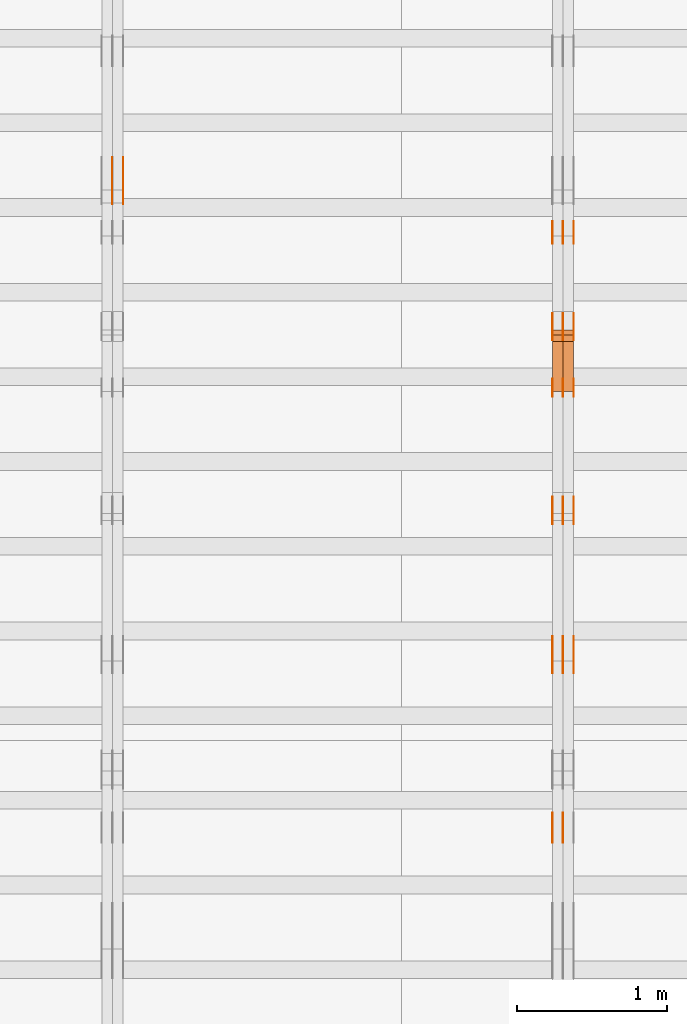
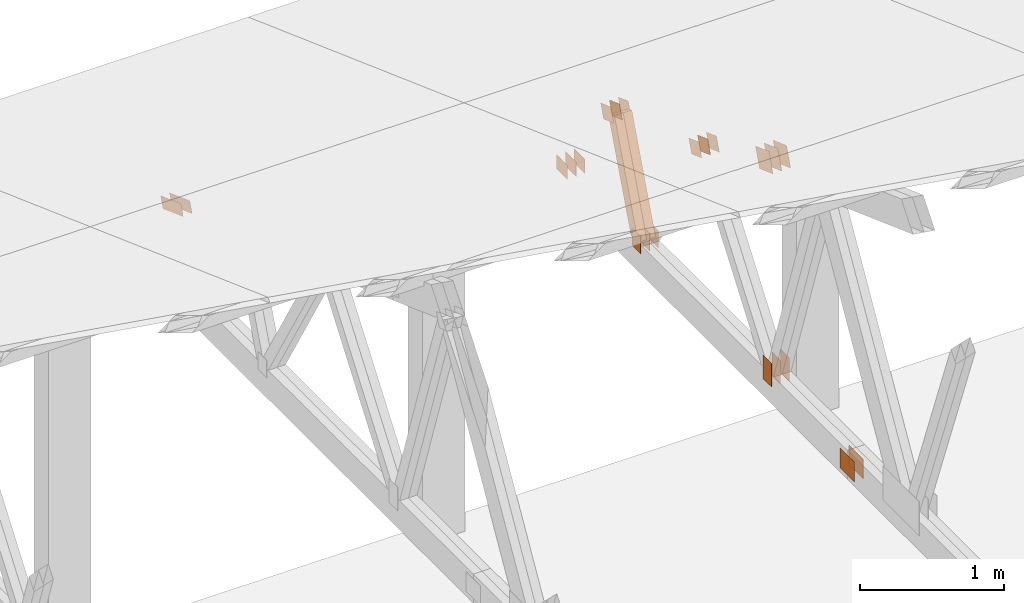
# One storey, part 166 of 189: 31 proxies.
"""IFC2X3 building model written with IfcOpenShell, lengths in millimetres."""

import ifcopenshell
import ifcopenshell.guid

model = None  # the IFC model being written
_history = None  # IfcOwnerHistory: only IFC2X3 demands one
_inside = {}  # id of a spatial element -> (the spatial element, [elements in it])
_under = {}  # id of a project, library or spatial element -> (it, [spatial elements below it])
_declared = {}  # id of a project -> (the project, [libraries it declares])
_typed = {}  # id of a type object -> (the type object, [elements of that type])
_made_of = {}  # id of a material, layer set ... -> (it, [elements and type objects made of it])


def new_model(schema):
    """Start an empty IFC model of exactly this schema.

    Asked for "IFC4X3", IfcOpenShell would pick the latest addendum, in which some entities
    have other attributes; the version numbers below select the first issue.
    IFC2X3 requires an IfcOwnerHistory on every rooted entity: one is made here for all.
    """
    global model, _history
    if schema == "IFC4X3":
        model = ifcopenshell.file(schema_version=(4, 3, 0, 0))
    else:
        model = ifcopenshell.file(schema=schema)
    _inside.clear()
    _under.clear()
    _declared.clear()
    _typed.clear()
    _made_of.clear()
    _history = None
    if model.schema == "IFC2X3":
        org = make("IfcOrganization", Name="unknown")
        user = make(
            "IfcPersonAndOrganization",
            ThePerson=make("IfcPerson", FamilyName="unknown"),
            TheOrganization=org,
        )
        app = make(
            "IfcApplication",
            ApplicationDeveloper=org,
            Version="unknown",
            ApplicationFullName="unknown",
            ApplicationIdentifier="unknown",
        )
        _history = make(
            "IfcOwnerHistory",
            OwningUser=user,
            OwningApplication=app,
            ChangeAction="ADDED",
            CreationDate=0,
        )
    return model


def make(cls, **values):
    """One entity of the class cls with the attributes given. An attribute that is None is left unset."""
    return model.create_entity(
        cls, **{name: value for name, value in values.items() if value is not None}
    )


def entity(cls, *values):
    """Any entity or typed value of the class cls, its attributes in the order of the schema. None: left unset."""
    e = model.create_entity(cls)
    for i, value in enumerate(values):
        if value is not None:
            e[i] = value
    return e


def rooted(cls, **values):
    """An entity with a GlobalId (a new one), such as an element, a storey or a relation."""
    return make(cls, GlobalId=ifcopenshell.guid.new(), OwnerHistory=_history, **values)


def si_unit(unit_type, name, prefix=None):
    """IfcSIUnit, for example si_unit("LENGTHUNIT", "METRE", prefix="MILLI")."""
    return make("IfcSIUnit", UnitType=unit_type, Prefix=prefix, Name=name)


def converted_unit(unit_type, name, factor, base, dimensions=None, offset=None):
    """IfcConversionBasedUnit, such as the inch: factor (a typed value) times the base unit."""
    return make(
        "IfcConversionBasedUnit"
        if offset is None
        else "IfcConversionBasedUnitWithOffset",
        ConversionOffset=offset,
        Dimensions=None
        if dimensions is None
        else entity("IfcDimensionalExponents", *dimensions),
        UnitType=unit_type,
        Name=name,
        ConversionFactor=make(
            "IfcMeasureWithUnit", ValueComponent=factor, UnitComponent=base
        ),
    )


def derived_unit(unit_type, elements):
    """IfcDerivedUnit: a product of units, each with its exponent."""
    return make(
        "IfcDerivedUnit",
        Elements=[
            make("IfcDerivedUnitElement", Unit=unit, Exponent=power)
            for unit, power in elements
        ],
        UnitType=unit_type,
    )


def assignment(units):
    """IfcUnitAssignment: the units of a project."""
    return None if units is None else make("IfcUnitAssignment", Units=units)


def point(xyz):
    """IfcCartesianPoint."""
    return None if xyz is None else make("IfcCartesianPoint", Coordinates=xyz)


def direction(xyz):
    """IfcDirection."""
    return None if xyz is None else make("IfcDirection", DirectionRatios=xyz)


def frame(location, z_axis=None, x_axis=None):
    """IfcAxis2Placement3D, a coordinate frame: its origin and axes. An axis left out is left unset."""
    return make(
        "IfcAxis2Placement3D",
        Location=point(location),
        Axis=direction(z_axis),
        RefDirection=direction(x_axis),
    )


def frame_2d(location, x_axis=None):
    """IfcAxis2Placement2D, a coordinate frame in the plane: its origin and x axis."""
    return make(
        "IfcAxis2Placement2D", Location=point(location), RefDirection=direction(x_axis)
    )


def origin():
    """The frame at (0, 0, 0) with its axes left unset."""
    return frame((0.0, 0.0, 0.0))


def origin_2d_with_axis():
    """The frame at (0, 0) in the plane with the x axis (1, 0) written out."""
    return frame_2d((0.0, 0.0), x_axis=(1.0, 0.0))


def place(relative_to, where):
    """IfcLocalPlacement: puts the frame where relative to a parent placement (None: the world)."""
    return make(
        "IfcLocalPlacement", PlacementRelTo=relative_to, RelativePlacement=where
    )


def context(
    kind, dimensions, precision=None, world=None, true_north=None, identifier=None
):
    """IfcGeometricRepresentationContext, for example the 3D "Model" context."""
    return make(
        "IfcGeometricRepresentationContext",
        ContextIdentifier=identifier,
        ContextType=kind,
        CoordinateSpaceDimension=dimensions,
        Precision=precision,
        WorldCoordinateSystem=world,
        TrueNorth=true_north,
    )


def subcontext(parent, identifier, kind, view, scale=None):
    """IfcGeometricRepresentationSubContext, for example "Body" below "Model"."""
    return make(
        "IfcGeometricRepresentationSubContext",
        ContextIdentifier=identifier,
        ContextType=kind,
        ParentContext=parent,
        TargetScale=scale,
        TargetView=view,
    )


def project(units=None, contexts=None):
    """IfcProject with its units and contexts."""
    return rooted(
        "IfcProject",
        Name="project",
        RepresentationContexts=contexts,
        UnitsInContext=assignment(units),
    )


def spatial(cls, under=None, at=None, **own):
    """A site, building, storey or space (cls), placed at a placement, below another one or the project."""
    s = rooted(cls, ObjectPlacement=at, **own)
    if under is not None:
        _under.setdefault(under.id(), (under, []))[1].append(s)
    return s


def polyline(points):
    """IfcPolyline through the points."""
    return make("IfcPolyline", Points=[point(p) for p in points])


def profile(cls, at=None, kind="AREA", **sizes):
    """A parametric profile (cls). Its sizes go by their IFC names, for example OverallWidth=200.0."""
    return make(cls, ProfileType=kind, Position=at, **sizes)


def rectangle(**sizes):
    """IfcRectangleProfileDef."""
    return profile("IfcRectangleProfileDef", **sizes)


def outline(outer, holes=None, kind="AREA"):
    """IfcArbitraryClosedProfileDef: a profile drawn as a closed curve; with holes, ...WithVoids."""
    if holes is None:
        return make("IfcArbitraryClosedProfileDef", ProfileType=kind, OuterCurve=outer)
    return make(
        "IfcArbitraryProfileDefWithVoids",
        ProfileType=kind,
        OuterCurve=outer,
        InnerCurves=holes,
    )


def extrude(swept, where, along, depth):
    """IfcExtrudedAreaSolid: the profile swept, set in the frame where, extruded along a direction by depth."""
    return make(
        "IfcExtrudedAreaSolid",
        SweptArea=swept,
        Position=where,
        ExtrudedDirection=direction(along),
        Depth=depth,
    )


def shape(context_of_items, identifier, shape_type, items):
    """IfcShapeRepresentation: the items that make up one representation, for example the "Body"."""
    return make(
        "IfcShapeRepresentation",
        ContextOfItems=context_of_items,
        RepresentationIdentifier=identifier,
        RepresentationType=shape_type,
        Items=items,
    )


def source(mapping_origin, context_of_items, identifier, shape_type, items):
    """IfcRepresentationMap: a shape defined once, which mapped items show again and again."""
    return make(
        "IfcRepresentationMap",
        MappingOrigin=mapping_origin,
        MappedRepresentation=shape(context_of_items, identifier, shape_type, items),
    )


def transform(
    local_origin,
    x_axis=None,
    y_axis=None,
    z_axis=None,
    scale=None,
    scale2=None,
    scale3=None,
    uniform=True,
):
    """IfcCartesianTransformationOperator3D, or its non-uniform kind. x_axis, y_axis, z_axis: its Axis1, 2, 3."""
    if uniform:
        return make(
            "IfcCartesianTransformationOperator3D",
            Axis1=direction(x_axis),
            Axis2=direction(y_axis),
            LocalOrigin=point(local_origin),
            Scale=scale,
            Axis3=direction(z_axis),
        )
    return make(
        "IfcCartesianTransformationOperator3DnonUniform",
        Axis1=direction(x_axis),
        Axis2=direction(y_axis),
        LocalOrigin=point(local_origin),
        Scale=scale,
        Axis3=direction(z_axis),
        Scale2=scale2,
        Scale3=scale3,
    )


def mapped(mapping_source, mapping_target):
    """IfcMappedItem: shows the shape of a source again, moved by a transform."""
    return make(
        "IfcMappedItem", MappingSource=mapping_source, MappingTarget=mapping_target
    )


def material(Name=None, Category=None):
    """IfcMaterial."""
    return make("IfcMaterial", Name=Name, Category=Category)


def made_of(thing, what):
    """Note that an element or type object is made of a material, layer set ...; save() writes the relation."""
    if what is not None:
        _made_of.setdefault(what.id(), (what, []))[1].append(thing)
    return thing


def type_object(cls, material=None, **own):
    """A type object (cls), such as IfcWallType, which elements share."""
    return made_of(rooted(cls, **own), material)


def type_shapes(of_type, sources):
    """Give a type object the sources (RepresentationMaps) that its elements show as mapped items."""
    of_type.RepresentationMaps = sources


def element(
    cls,
    number,
    at=None,
    inside=None,
    cuts=None,
    type_object=None,
    material=None,
    context=None,
    identifier="Body",
    shape_type=None,
    held_by="IfcProductDefinitionShape",
    body=None,
    shapes=None,
    **own,
):
    """One element of the class cls, such as IfcWall. Its Tag is "e" and its number.

    at: its placement. inside: the storey or other place that contains it. cuts: it is an
    opening in that element (IfcRelVoidsElement). A single representation is given by context,
    identifier, shape_type and body (its items); several are given by shapes. held_by: the class
    of the entity that holds the representations. save() writes the other relations.
    """
    e = rooted(cls, Tag="e%d" % number, ObjectPlacement=at, **own)
    if body is not None:
        shapes = [shape(context, identifier, shape_type, body)]
    if shapes is not None:
        e.Representation = make(held_by, Representations=shapes)
    if inside is not None:
        _inside.setdefault(inside.id(), (inside, []))[1].append(e)
    if cuts is not None:
        rooted(
            "IfcRelVoidsElement", RelatingBuildingElement=cuts, RelatedOpeningElement=e
        )
    if type_object is not None:
        _typed.setdefault(type_object.id(), (type_object, []))[1].append(e)
    return made_of(e, material)


def aggregate(whole, parts):
    """IfcRelAggregates: a whole, such as a stair, and the parts it consists of."""
    return rooted("IfcRelAggregates", RelatingObject=whole, RelatedObjects=parts)


def save(model, path):
    """Write the relations noted so far, then the file.

    IfcRelAggregates (storeys below a building ...), IfcRelContainedInSpatialStructure (elements
    in a storey), IfcRelDefinesByType, IfcRelAssociatesMaterial and IfcRelDeclares: one each for
    every whole, place, type object, material and project.
    """
    for whole, parts in _under.values():
        aggregate(whole, parts)
    for where, things in _inside.values():
        rooted(
            "IfcRelContainedInSpatialStructure",
            RelatedElements=things,
            RelatingStructure=where,
        )
    for kind, things in _typed.values():
        rooted("IfcRelDefinesByType", RelatedObjects=things, RelatingType=kind)
    for what, things in _made_of.values():
        rooted("IfcRelAssociatesMaterial", RelatedObjects=things, RelatingMaterial=what)
    for by, libraries in _declared.values():
        rooted("IfcRelDeclares", RelatingContext=by, RelatedDefinitions=libraries)
    model.write(path)


model = new_model("IFC2X3")

# Units and contexts
model_context = context("Model", 3, precision=0.01, world=origin(), true_north=direction((6.12303176911189e-17, 1.0)))
body_context = subcontext(model_context, "Body", "Model", "MODEL_VIEW")
ifc_project = project(units=[si_unit("LENGTHUNIT", "METRE", prefix="MILLI"), si_unit("AREAUNIT", "SQUARE_METRE"), si_unit("VOLUMEUNIT", "CUBIC_METRE"), converted_unit("PLANEANGLEUNIT", "DEGREE", entity("IfcRatioMeasure", 0.0174532925199433), si_unit("PLANEANGLEUNIT", "RADIAN"), dimensions=[0, 0, 0, 0, 0, 0, 0]), si_unit("MASSUNIT", "GRAM", prefix="KILO"), derived_unit("MASSDENSITYUNIT", [(si_unit("MASSUNIT", "GRAM", prefix="KILO"), 1), (si_unit("LENGTHUNIT", "METRE"), -3)]), si_unit("TIMEUNIT", "SECOND"), si_unit("FREQUENCYUNIT", "HERTZ"), si_unit("THERMODYNAMICTEMPERATUREUNIT", "DEGREE_CELSIUS"), derived_unit("THERMALTRANSMITTANCEUNIT", [(si_unit("MASSUNIT", "GRAM", prefix="KILO"), 1), (si_unit("THERMODYNAMICTEMPERATUREUNIT", "KELVIN"), -1), (si_unit("TIMEUNIT", "SECOND"), -3)]), derived_unit("VOLUMETRICFLOWRATEUNIT", [(si_unit("LENGTHUNIT", "METRE"), 3), (si_unit("TIMEUNIT", "SECOND"), -1)]), si_unit("ELECTRICCURRENTUNIT", "AMPERE"), si_unit("ELECTRICVOLTAGEUNIT", "VOLT"), si_unit("POWERUNIT", "WATT"), si_unit("FORCEUNIT", "NEWTON"), si_unit("ILLUMINANCEUNIT", "LUX"), si_unit("LUMINOUSFLUXUNIT", "LUMEN"), si_unit("LUMINOUSINTENSITYUNIT", "CANDELA"), derived_unit("USERDEFINED", [(si_unit("MASSUNIT", "GRAM", prefix="KILO"), -1), (si_unit("LENGTHUNIT", "METRE"), -2), (si_unit("TIMEUNIT", "SECOND"), 3), (si_unit("LUMINOUSFLUXUNIT", "LUMEN"), 1)]), derived_unit("LINEARVELOCITYUNIT", [(si_unit("LENGTHUNIT", "METRE"), 1), (si_unit("TIMEUNIT", "SECOND"), -1)]), si_unit("PRESSUREUNIT", "PASCAL"), derived_unit("USERDEFINED", [(si_unit("LENGTHUNIT", "METRE"), -2), (si_unit("MASSUNIT", "GRAM", prefix="KILO"), 1), (si_unit("TIMEUNIT", "SECOND"), -2)])], contexts=[model_context])

# Site, building, storey
site_placement = place(None, origin())
site = spatial("IfcSite", under=ifc_project, at=site_placement, CompositionType="ELEMENT")
building_placement = place(site_placement, origin())
building = spatial("IfcBuilding", under=site, at=building_placement, CompositionType="ELEMENT")
storey_placement = place(building_placement, origin())
storey = spatial("IfcBuildingStorey", under=building, at=storey_placement, Name="Default", CompositionType="ELEMENT", Elevation=0.0)

# Proxies
ifc_material_1 = material(Name="IfcSurfaceStyle #200990")
building_element_proxy_type_1 = type_object("IfcBuildingElementProxyType", PredefinedType="NOTDEFINED", material=ifc_material_1)
shared_shape_1 = source(origin(), body_context, "Body", "SweptSolid", [
    extrude(rectangle(XDim=200.0, YDim=120.0, at=origin_2d_with_axis()), frame((100.0, 60.0002296775929, 0.0), z_axis=(0.0, 0.0, 1.0), x_axis=(-1.0, 0.0, 0.0)), (0.0, 0.0, 1.0), 1.3),
])
type_shapes(building_element_proxy_type_1, [shared_shape_1])
proxy_1_placement = place(building_placement, frame((36301.3, 24619.3435203224, 145.0), z_axis=(-1.0, 0.0, 0.0), x_axis=(0.0, 0.0, 1.0)))
element("IfcBuildingElementProxy", 1, at=proxy_1_placement, inside=storey, type_object=building_element_proxy_type_1, material=ifc_material_1, context=body_context, shape_type="MappedRepresentation", body=[
    mapped(shared_shape_1, transform((0.0, 0.0, 0.0), scale=1.0)),
])
ifc_material_2 = material(Name="IfcSurfaceStyle #200933")
building_element_proxy_type_2 = type_object("IfcBuildingElementProxyType", PredefinedType="NOTDEFINED", material=ifc_material_2)
shared_shape_2 = source(origin(), body_context, "Body", "SweptSolid", [
    extrude(rectangle(XDim=200.0, YDim=120.0, at=origin_2d_with_axis()), frame((100.0, 60.0002296775929, 0.0), z_axis=(0.0, 0.0, 1.0), x_axis=(-1.0, 0.0, 0.0)), (0.0, 0.0, 1.0), 1.29999999999998),
])
type_shapes(building_element_proxy_type_2, [shared_shape_2])
proxy_2_placement = place(building_placement, frame((36230.0, 24619.3435203224, 145.0), z_axis=(-1.0, 0.0, 0.0), x_axis=(0.0, 0.0, 1.0)))
element("IfcBuildingElementProxy", 2, at=proxy_2_placement, inside=storey, type_object=building_element_proxy_type_2, material=ifc_material_2, context=body_context, shape_type="MappedRepresentation", body=[
    mapped(shared_shape_2, transform((0.0, 0.0, 0.0), scale=1.0)),
])
ifc_material_3 = material(Name="IfcSurfaceStyle #200876")
building_element_proxy_type_3 = type_object("IfcBuildingElementProxyType", PredefinedType="NOTDEFINED", material=ifc_material_3)
shared_shape_3 = source(origin(), body_context, "Body", "SweptSolid", [
    extrude(rectangle(XDim=200.0, YDim=120.0, at=origin_2d_with_axis()), frame((100.0, 60.0002296775929, 0.0), z_axis=(0.0, 0.0, 1.0), x_axis=(-1.0, 0.0, 0.0)), (0.0, 0.0, 1.0), 1.29999999999998),
])
type_shapes(building_element_proxy_type_3, [shared_shape_3])
proxy_3_placement = place(building_placement, frame((36231.3, 24619.3435203224, 145.0), z_axis=(-1.0, 0.0, 0.0), x_axis=(0.0, 0.0, 1.0)))
element("IfcBuildingElementProxy", 3, at=proxy_3_placement, inside=storey, type_object=building_element_proxy_type_3, material=ifc_material_3, context=body_context, shape_type="MappedRepresentation", body=[
    mapped(shared_shape_3, transform((0.0, 0.0, 0.0), scale=1.0)),
])
ifc_material_4 = material(Name="IfcSurfaceStyle #200819")
building_element_proxy_type_4 = type_object("IfcBuildingElementProxyType", PredefinedType="NOTDEFINED", material=ifc_material_4)
shared_shape_4 = source(origin(), body_context, "Body", "SweptSolid", [
    extrude(rectangle(XDim=200.0, YDim=120.0, at=origin_2d_with_axis()), frame((100.0, 60.0002296775929, 0.0), z_axis=(0.0, 0.0, 1.0), x_axis=(-1.0, 0.0, 0.0)), (0.0, 0.0, 1.0), 1.29999999999999),
])
type_shapes(building_element_proxy_type_4, [shared_shape_4])
proxy_4_placement = place(building_placement, frame((36160.0, 24619.3435203224, 145.0), z_axis=(-1.0, 0.0, 0.0), x_axis=(0.0, 0.0, 1.0)))
element("IfcBuildingElementProxy", 4, at=proxy_4_placement, inside=storey, type_object=building_element_proxy_type_4, material=ifc_material_4, context=body_context, shape_type="MappedRepresentation", body=[
    mapped(shared_shape_4, transform((0.0, 0.0, 0.0), scale=1.0)),
])
ifc_material_5 = material(Name="IfcSurfaceStyle #200306")
building_element_proxy_type_5 = type_object("IfcBuildingElementProxyType", PredefinedType="NOTDEFINED", material=ifc_material_5)
shared_shape_5 = source(origin(), body_context, "Body", "SweptSolid", [
    extrude(outline(polyline([(-74.9999475298494, -60.0), (75.0000042257432, -60.0), (74.9999684051025, 60.0), (-75.0000251009963, 60.0), (-74.9999475298494, -60.0)])), frame((75.0000607644577, 60.0000865490217, 0.0), z_axis=(0.0, 0.0, 1.0), x_axis=(-1.0, 0.0, 0.0)), (0.0, 0.0, 1.0), 1.3),
])
type_shapes(building_element_proxy_type_5, [shared_shape_5])
proxy_5_placement = place(building_placement, frame((36301.3, 25732.0586805394, 1446.84420669249), z_axis=(-1.0, 0.0, 0.0), x_axis=(0.0, -0.939692620785908, 0.342020143325669)))
element("IfcBuildingElementProxy", 5, at=proxy_5_placement, inside=storey, type_object=building_element_proxy_type_5, material=ifc_material_5, context=body_context, shape_type="MappedRepresentation", body=[
    mapped(shared_shape_5, transform((0.0, 0.0, 0.0), scale=1.0)),
])
ifc_material_6 = material(Name="IfcSurfaceStyle #200249")
building_element_proxy_type_6 = type_object("IfcBuildingElementProxyType", PredefinedType="NOTDEFINED", material=ifc_material_6)
shared_shape_6 = source(origin(), body_context, "Body", "SweptSolid", [
    extrude(outline(polyline([(-74.9999475298494, -60.0), (75.0000042257432, -60.0), (74.9999684051025, 60.0), (-75.0000251009963, 60.0), (-74.9999475298494, -60.0)])), frame((75.0000607644577, 60.0000865490217, 0.0), z_axis=(0.0, 0.0, 1.0), x_axis=(-1.0, 0.0, 0.0)), (0.0, 0.0, 1.0), 1.29999999999999),
])
type_shapes(building_element_proxy_type_6, [shared_shape_6])
proxy_6_placement = place(building_placement, frame((36230.0, 25732.0586805394, 1446.84420669249), z_axis=(-1.0, 0.0, 0.0), x_axis=(0.0, -0.939692620785908, 0.342020143325669)))
element("IfcBuildingElementProxy", 6, at=proxy_6_placement, inside=storey, type_object=building_element_proxy_type_6, material=ifc_material_6, context=body_context, shape_type="MappedRepresentation", body=[
    mapped(shared_shape_6, transform((0.0, 0.0, 0.0), scale=1.0)),
])
ifc_material_7 = material(Name="IfcSurfaceStyle #200192")
building_element_proxy_type_7 = type_object("IfcBuildingElementProxyType", PredefinedType="NOTDEFINED", material=ifc_material_7)
shared_shape_7 = source(origin(), body_context, "Body", "SweptSolid", [
    extrude(outline(polyline([(-74.9999475298494, -60.0), (75.0000042257432, -60.0), (74.9999684051025, 60.0), (-75.0000251009963, 60.0), (-74.9999475298494, -60.0)])), frame((75.0000607644577, 60.0000865490217, 0.0), z_axis=(0.0, 0.0, 1.0), x_axis=(-1.0, 0.0, 0.0)), (0.0, 0.0, 1.0), 1.29999999999999),
])
type_shapes(building_element_proxy_type_7, [shared_shape_7])
proxy_7_placement = place(building_placement, frame((36231.3, 25732.0586805394, 1446.84420669249), z_axis=(-1.0, 0.0, 0.0), x_axis=(0.0, -0.939692620785908, 0.342020143325669)))
element("IfcBuildingElementProxy", 7, at=proxy_7_placement, inside=storey, type_object=building_element_proxy_type_7, material=ifc_material_7, context=body_context, shape_type="MappedRepresentation", body=[
    mapped(shared_shape_7, transform((0.0, 0.0, 0.0), scale=1.0)),
])
ifc_material_8 = material(Name="IfcSurfaceStyle #200135")
building_element_proxy_type_8 = type_object("IfcBuildingElementProxyType", PredefinedType="NOTDEFINED", material=ifc_material_8)
shared_shape_8 = source(origin(), body_context, "Body", "SweptSolid", [
    extrude(outline(polyline([(-74.9999475298494, -60.0), (75.0000042257432, -60.0), (74.9999684051025, 60.0), (-75.0000251009963, 60.0), (-74.9999475298494, -60.0)])), frame((75.0000607644577, 60.0000865490217, 0.0), z_axis=(0.0, 0.0, 1.0), x_axis=(-1.0, 0.0, 0.0)), (0.0, 0.0, 1.0), 1.29999999999999),
])
type_shapes(building_element_proxy_type_8, [shared_shape_8])
proxy_8_placement = place(building_placement, frame((36160.0, 25732.0586805394, 1446.84420669249), z_axis=(-1.0, 0.0, 0.0), x_axis=(0.0, -0.939692620785908, 0.342020143325669)))
element("IfcBuildingElementProxy", 8, at=proxy_8_placement, inside=storey, type_object=building_element_proxy_type_8, material=ifc_material_8, context=body_context, shape_type="MappedRepresentation", body=[
    mapped(shared_shape_8, transform((0.0, 0.0, 0.0), scale=1.0)),
])
ifc_material_9 = material(Name="IfcSurfaceStyle #200078")
building_element_proxy_type_9 = type_object("IfcBuildingElementProxyType", PredefinedType="NOTDEFINED", material=ifc_material_9)
shared_shape_9 = source(origin(), body_context, "Body", "SweptSolid", [
    extrude(rectangle(XDim=150.0, YDim=120.0, at=frame_2d((-7.105427357601e-15, 0.0), x_axis=(1.0, 0.0))), frame((75.0, 60.0, 0.0), z_axis=(0.0, 0.0, 1.0), x_axis=(-1.0, 0.0, 0.0)), (0.0, 0.0, 1.0), 1.3),
])
type_shapes(building_element_proxy_type_9, [shared_shape_9])
proxy_9_placement = place(building_placement, frame((36301.3, 26439.0083007813, 170.0), z_axis=(-1.0, 0.0, 0.0), x_axis=(0.0, 0.0, 1.0)))
element("IfcBuildingElementProxy", 9, at=proxy_9_placement, inside=storey, type_object=building_element_proxy_type_9, material=ifc_material_9, context=body_context, shape_type="MappedRepresentation", body=[
    mapped(shared_shape_9, transform((0.0, 0.0, 0.0), scale=1.0)),
])
ifc_material_10 = material(Name="IfcSurfaceStyle #200021")
building_element_proxy_type_10 = type_object("IfcBuildingElementProxyType", PredefinedType="NOTDEFINED", material=ifc_material_10)
shared_shape_10 = source(origin(), body_context, "Body", "SweptSolid", [
    extrude(rectangle(XDim=150.0, YDim=120.0, at=frame_2d((-7.105427357601e-15, 0.0), x_axis=(1.0, 0.0))), frame((75.0, 60.0, 0.0), z_axis=(0.0, 0.0, 1.0), x_axis=(-1.0, 0.0, 0.0)), (0.0, 0.0, 1.0), 1.29999999999999),
])
type_shapes(building_element_proxy_type_10, [shared_shape_10])
proxy_10_placement = place(building_placement, frame((36230.0, 26439.0083007813, 170.0), z_axis=(-1.0, 0.0, 0.0), x_axis=(0.0, 0.0, 1.0)))
element("IfcBuildingElementProxy", 10, at=proxy_10_placement, inside=storey, type_object=building_element_proxy_type_10, material=ifc_material_10, context=body_context, shape_type="MappedRepresentation", body=[
    mapped(shared_shape_10, transform((0.0, 0.0, 0.0), scale=1.0)),
])
ifc_material_11 = material(Name="IfcSurfaceStyle #199964")
building_element_proxy_type_11 = type_object("IfcBuildingElementProxyType", PredefinedType="NOTDEFINED", material=ifc_material_11)
shared_shape_11 = source(origin(), body_context, "Body", "SweptSolid", [
    extrude(rectangle(XDim=150.0, YDim=120.0, at=frame_2d((-7.105427357601e-15, 0.0), x_axis=(1.0, 0.0))), frame((75.0, 60.0, 0.0), z_axis=(0.0, 0.0, 1.0), x_axis=(-1.0, 0.0, 0.0)), (0.0, 0.0, 1.0), 1.29999999999999),
])
type_shapes(building_element_proxy_type_11, [shared_shape_11])
proxy_11_placement = place(building_placement, frame((36231.3, 26439.0083007813, 170.0), z_axis=(-1.0, 0.0, 0.0), x_axis=(0.0, 0.0, 1.0)))
element("IfcBuildingElementProxy", 11, at=proxy_11_placement, inside=storey, type_object=building_element_proxy_type_11, material=ifc_material_11, context=body_context, shape_type="MappedRepresentation", body=[
    mapped(shared_shape_11, transform((0.0, 0.0, 0.0), scale=1.0)),
])
ifc_material_12 = material(Name="IfcSurfaceStyle #199907")
building_element_proxy_type_12 = type_object("IfcBuildingElementProxyType", PredefinedType="NOTDEFINED", material=ifc_material_12)
shared_shape_12 = source(origin(), body_context, "Body", "SweptSolid", [
    extrude(rectangle(XDim=150.0, YDim=120.0, at=frame_2d((-7.105427357601e-15, 0.0), x_axis=(1.0, 0.0))), frame((75.0, 60.0, 0.0), z_axis=(0.0, 0.0, 1.0), x_axis=(-1.0, 0.0, 0.0)), (0.0, 0.0, 1.0), 1.29999999999999),
])
type_shapes(building_element_proxy_type_12, [shared_shape_12])
proxy_12_placement = place(building_placement, frame((36160.0, 26439.0083007813, 170.0), z_axis=(-1.0, 0.0, 0.0), x_axis=(0.0, 0.0, 1.0)))
element("IfcBuildingElementProxy", 12, at=proxy_12_placement, inside=storey, type_object=building_element_proxy_type_12, material=ifc_material_12, context=body_context, shape_type="MappedRepresentation", body=[
    mapped(shared_shape_12, transform((0.0, 0.0, 0.0), scale=1.0)),
])
ifc_material_13 = material(Name="IfcSurfaceStyle #199394")
building_element_proxy_type_13 = type_object("IfcBuildingElementProxyType", PredefinedType="NOTDEFINED", material=ifc_material_13)
shared_shape_13 = source(origin(), body_context, "Body", "SweptSolid", [
    extrude(outline(polyline([(-74.9999684051023, -60.0), (75.0000251009964, -60.0), (74.9999475298495, 60.0), (-75.0000042257435, 60.0), (-74.9999684051023, -60.0)])), frame((75.0000251009964, 60.0000006265238, 0.0), z_axis=(0.0, 0.0, 1.0), x_axis=(-1.0, 0.0, 0.0)), (0.0, 0.0, 1.0), 1.3),
])
type_shapes(building_element_proxy_type_13, [shared_shape_13])
proxy_13_placement = place(building_placement, frame((36301.3, 26956.490053282, 1001.18769055967), z_axis=(-1.0, 0.0, 0.0), x_axis=(0.0, -0.939692620785908, 0.342020143325669)))
element("IfcBuildingElementProxy", 13, at=proxy_13_placement, inside=storey, type_object=building_element_proxy_type_13, material=ifc_material_13, context=body_context, shape_type="MappedRepresentation", body=[
    mapped(shared_shape_13, transform((0.0, 0.0, 0.0), scale=1.0)),
])
ifc_material_14 = material(Name="IfcSurfaceStyle #199337")
building_element_proxy_type_14 = type_object("IfcBuildingElementProxyType", PredefinedType="NOTDEFINED", material=ifc_material_14)
shared_shape_14 = source(origin(), body_context, "Body", "SweptSolid", [
    extrude(outline(polyline([(-74.9999684051023, -60.0), (75.0000251009964, -60.0), (74.9999475298495, 60.0), (-75.0000042257435, 60.0), (-74.9999684051023, -60.0)])), frame((75.0000251009964, 60.0000006265238, 0.0), z_axis=(0.0, 0.0, 1.0), x_axis=(-1.0, 0.0, 0.0)), (0.0, 0.0, 1.0), 1.29999999999999),
])
type_shapes(building_element_proxy_type_14, [shared_shape_14])
proxy_14_placement = place(building_placement, frame((36230.0, 26956.490053282, 1001.18769055967), z_axis=(-1.0, 0.0, 0.0), x_axis=(0.0, -0.939692620785908, 0.342020143325669)))
element("IfcBuildingElementProxy", 14, at=proxy_14_placement, inside=storey, type_object=building_element_proxy_type_14, material=ifc_material_14, context=body_context, shape_type="MappedRepresentation", body=[
    mapped(shared_shape_14, transform((0.0, 0.0, 0.0), scale=1.0)),
])
ifc_material_15 = material(Name="IfcSurfaceStyle #199280")
building_element_proxy_type_15 = type_object("IfcBuildingElementProxyType", PredefinedType="NOTDEFINED", material=ifc_material_15)
shared_shape_15 = source(origin(), body_context, "Body", "SweptSolid", [
    extrude(outline(polyline([(-74.9999684051023, -60.0), (75.0000251009964, -60.0), (74.9999475298495, 60.0), (-75.0000042257435, 60.0), (-74.9999684051023, -60.0)])), frame((75.0000251009964, 60.0000006265238, 0.0), z_axis=(0.0, 0.0, 1.0), x_axis=(-1.0, 0.0, 0.0)), (0.0, 0.0, 1.0), 1.29999999999999),
])
type_shapes(building_element_proxy_type_15, [shared_shape_15])
proxy_15_placement = place(building_placement, frame((36231.3, 26956.490053282, 1001.18769055967), z_axis=(-1.0, 0.0, 0.0), x_axis=(0.0, -0.939692620785908, 0.342020143325669)))
element("IfcBuildingElementProxy", 15, at=proxy_15_placement, inside=storey, type_object=building_element_proxy_type_15, material=ifc_material_15, context=body_context, shape_type="MappedRepresentation", body=[
    mapped(shared_shape_15, transform((0.0, 0.0, 0.0), scale=1.0)),
])
ifc_material_16 = material(Name="IfcSurfaceStyle #199223")
building_element_proxy_type_16 = type_object("IfcBuildingElementProxyType", PredefinedType="NOTDEFINED", material=ifc_material_16)
shared_shape_16 = source(origin(), body_context, "Body", "SweptSolid", [
    extrude(outline(polyline([(-74.9999684051023, -60.0), (75.0000251009964, -60.0), (74.9999475298495, 60.0), (-75.0000042257435, 60.0), (-74.9999684051023, -60.0)])), frame((75.0000251009964, 60.0000006265238, 0.0), z_axis=(0.0, 0.0, 1.0), x_axis=(-1.0, 0.0, 0.0)), (0.0, 0.0, 1.0), 1.29999999999999),
])
type_shapes(building_element_proxy_type_16, [shared_shape_16])
proxy_16_placement = place(building_placement, frame((36160.0, 26956.490053282, 1001.18769055967), z_axis=(-1.0, 0.0, 0.0), x_axis=(0.0, -0.939692620785908, 0.342020143325669)))
element("IfcBuildingElementProxy", 16, at=proxy_16_placement, inside=storey, type_object=building_element_proxy_type_16, material=ifc_material_16, context=body_context, shape_type="MappedRepresentation", body=[
    mapped(shared_shape_16, transform((0.0, 0.0, 0.0), scale=1.0)),
])
ifc_material_17 = material(Name="IfcSurfaceStyle #199166")
building_element_proxy_type_17 = type_object("IfcBuildingElementProxyType", PredefinedType="NOTDEFINED", material=ifc_material_17)
shared_shape_17 = source(origin(), body_context, "Body", "SweptSolid", [
    extrude(rectangle(XDim=150.0, YDim=120.0, at=origin_2d_with_axis()), frame((75.0, 60.0, 0.0), z_axis=(0.0, 0.0, 1.0), x_axis=(-1.0, 0.0, 0.0)), (0.0, 0.0, 1.0), 1.3),
])
type_shapes(building_element_proxy_type_17, [shared_shape_17])
proxy_17_placement = place(building_placement, frame((36301.3, 27607.3129882813, 185.0), z_axis=(-1.0, 0.0, 0.0), x_axis=(0.0, -1.0, 0.0)))
element("IfcBuildingElementProxy", 17, at=proxy_17_placement, inside=storey, type_object=building_element_proxy_type_17, material=ifc_material_17, context=body_context, shape_type="MappedRepresentation", body=[
    mapped(shared_shape_17, transform((0.0, 0.0, 0.0), scale=1.0)),
])
ifc_material_18 = material(Name="IfcSurfaceStyle #199109")
building_element_proxy_type_18 = type_object("IfcBuildingElementProxyType", PredefinedType="NOTDEFINED", material=ifc_material_18)
shared_shape_18 = source(origin(), body_context, "Body", "SweptSolid", [
    extrude(rectangle(XDim=150.0, YDim=120.0, at=origin_2d_with_axis()), frame((75.0, 60.0, 0.0), z_axis=(0.0, 0.0, 1.0), x_axis=(-1.0, 0.0, 0.0)), (0.0, 0.0, 1.0), 1.29999999999999),
])
type_shapes(building_element_proxy_type_18, [shared_shape_18])
proxy_18_placement = place(building_placement, frame((36230.0, 27607.3129882813, 185.0), z_axis=(-1.0, 0.0, 0.0), x_axis=(0.0, -1.0, 0.0)))
element("IfcBuildingElementProxy", 18, at=proxy_18_placement, inside=storey, type_object=building_element_proxy_type_18, material=ifc_material_18, context=body_context, shape_type="MappedRepresentation", body=[
    mapped(shared_shape_18, transform((0.0, 0.0, 0.0), scale=1.0)),
])
ifc_material_19 = material(Name="IfcSurfaceStyle #199052")
building_element_proxy_type_19 = type_object("IfcBuildingElementProxyType", PredefinedType="NOTDEFINED", material=ifc_material_19)
shared_shape_19 = source(origin(), body_context, "Body", "SweptSolid", [
    extrude(rectangle(XDim=150.0, YDim=120.0, at=origin_2d_with_axis()), frame((75.0, 60.0, 0.0), z_axis=(0.0, 0.0, 1.0), x_axis=(-1.0, 0.0, 0.0)), (0.0, 0.0, 1.0), 1.29999999999999),
])
type_shapes(building_element_proxy_type_19, [shared_shape_19])
proxy_19_placement = place(building_placement, frame((36231.3, 27607.3129882813, 185.0), z_axis=(-1.0, 0.0, 0.0), x_axis=(0.0, -1.0, 0.0)))
element("IfcBuildingElementProxy", 19, at=proxy_19_placement, inside=storey, type_object=building_element_proxy_type_19, material=ifc_material_19, context=body_context, shape_type="MappedRepresentation", body=[
    mapped(shared_shape_19, transform((0.0, 0.0, 0.0), scale=1.0)),
])
ifc_material_20 = material(Name="IfcSurfaceStyle #198995")
building_element_proxy_type_20 = type_object("IfcBuildingElementProxyType", PredefinedType="NOTDEFINED", material=ifc_material_20)
shared_shape_20 = source(origin(), body_context, "Body", "SweptSolid", [
    extrude(rectangle(XDim=150.0, YDim=120.0, at=origin_2d_with_axis()), frame((75.0, 60.0, 0.0), z_axis=(0.0, 0.0, 1.0), x_axis=(-1.0, 0.0, 0.0)), (0.0, 0.0, 1.0), 1.29999999999999),
])
type_shapes(building_element_proxy_type_20, [shared_shape_20])
proxy_20_placement = place(building_placement, frame((36160.0, 27607.3129882813, 185.0), z_axis=(-1.0, 0.0, 0.0), x_axis=(0.0, -1.0, 0.0)))
element("IfcBuildingElementProxy", 20, at=proxy_20_placement, inside=storey, type_object=building_element_proxy_type_20, material=ifc_material_20, context=body_context, shape_type="MappedRepresentation", body=[
    mapped(shared_shape_20, transform((0.0, 0.0, 0.0), scale=1.0)),
])
ifc_material_21 = material(Name="IfcSurfaceStyle #197285")
building_element_proxy_type_21 = type_object("IfcBuildingElementProxyType", PredefinedType="NOTDEFINED", material=ifc_material_21)
shared_shape_21 = source(origin(), body_context, "Body", "SweptSolid", [
    extrude(rectangle(XDim=200.0, YDim=168.0, at=origin_2d_with_axis()), frame((100.0, 84.0, 0.0), z_axis=(0.0, 0.0, 1.0), x_axis=(-1.0, 0.0, 0.0)), (0.0, 0.0, 1.0), 1.29999999999998),
])
type_shapes(building_element_proxy_type_21, [shared_shape_21])
proxy_21_placement = place(building_placement, frame((36230.0, 23470.0, 206.5), z_axis=(-1.0, 0.0, 0.0), x_axis=(0.0, 1.0, 0.0)))
element("IfcBuildingElementProxy", 21, at=proxy_21_placement, inside=storey, type_object=building_element_proxy_type_21, material=ifc_material_21, context=body_context, shape_type="MappedRepresentation", body=[
    mapped(shared_shape_21, transform((0.0, 0.0, 0.0), scale=1.0)),
])
ifc_material_22 = material(Name="IfcSurfaceStyle #197228")
building_element_proxy_type_22 = type_object("IfcBuildingElementProxyType", PredefinedType="NOTDEFINED", material=ifc_material_22)
shared_shape_22 = source(origin(), body_context, "Body", "SweptSolid", [
    extrude(rectangle(XDim=200.0, YDim=168.0, at=origin_2d_with_axis()), frame((100.0, 84.0, 0.0), z_axis=(0.0, 0.0, 1.0), x_axis=(-1.0, 0.0, 0.0)), (0.0, 0.0, 1.0), 1.29999999999998),
])
type_shapes(building_element_proxy_type_22, [shared_shape_22])
proxy_22_placement = place(building_placement, frame((36231.3, 23470.0, 206.5), z_axis=(-1.0, 0.0, 0.0), x_axis=(0.0, 1.0, 0.0)))
element("IfcBuildingElementProxy", 22, at=proxy_22_placement, inside=storey, type_object=building_element_proxy_type_22, material=ifc_material_22, context=body_context, shape_type="MappedRepresentation", body=[
    mapped(shared_shape_22, transform((0.0, 0.0, 0.0), scale=1.0)),
])
ifc_material_23 = material(Name="IfcSurfaceStyle #197171")
building_element_proxy_type_23 = type_object("IfcBuildingElementProxyType", PredefinedType="NOTDEFINED", material=ifc_material_23)
shared_shape_23 = source(origin(), body_context, "Body", "SweptSolid", [
    extrude(rectangle(XDim=200.0, YDim=168.0, at=origin_2d_with_axis()), frame((100.0, 84.0, 0.0), z_axis=(0.0, 0.0, 1.0), x_axis=(-1.0, 0.0, 0.0)), (0.0, 0.0, 1.0), 1.29999999999999),
])
type_shapes(building_element_proxy_type_23, [shared_shape_23])
proxy_23_placement = place(building_placement, frame((36160.0, 23470.0, 206.5), z_axis=(-1.0, 0.0, 0.0), x_axis=(0.0, 1.0, 0.0)))
element("IfcBuildingElementProxy", 23, at=proxy_23_placement, inside=storey, type_object=building_element_proxy_type_23, material=ifc_material_23, context=body_context, shape_type="MappedRepresentation", body=[
    mapped(shared_shape_23, transform((0.0, 0.0, 0.0), scale=1.0)),
])
ifc_material_24 = material(Name="IfcSurfaceStyle #195182")
building_element_proxy_type_24 = type_object("IfcBuildingElementProxyType", PredefinedType="NOTDEFINED", material=ifc_material_24)
shared_shape_24 = source(origin(), body_context, "Body", "SweptSolid", [
    extrude(outline(polyline([(-99.9999065788418, -84.0000755647729), (99.9999734279406, -84.0000755647729), (99.9999483293475, 84.000075564773), (-100.000015178446, 84.000075564773), (-99.9999065788418, -84.0000755647729)])), frame((100.000157783747, 84.0001144608011, 0.0), z_axis=(0.0, 0.0, 1.0), x_axis=(-1.0, 0.0, 0.0)), (0.0, 0.0, 1.0), 1.3),
])
type_shapes(building_element_proxy_type_24, [shared_shape_24])
proxy_24_placement = place(building_placement, frame((36301.3, 24788.4767593228, 1895.10136879206), z_axis=(-1.0, 0.0, 0.0), x_axis=(0.0, -0.939692620785908, 0.342020143325669)))
element("IfcBuildingElementProxy", 24, at=proxy_24_placement, inside=storey, type_object=building_element_proxy_type_24, material=ifc_material_24, context=body_context, shape_type="MappedRepresentation", body=[
    mapped(shared_shape_24, transform((0.0, 0.0, 0.0), scale=1.0)),
])
ifc_material_25 = material(Name="IfcSurfaceStyle #195125")
building_element_proxy_type_25 = type_object("IfcBuildingElementProxyType", PredefinedType="NOTDEFINED", material=ifc_material_25)
shared_shape_25 = source(origin(), body_context, "Body", "SweptSolid", [
    extrude(outline(polyline([(-99.9999065788418, -84.0000755647729), (99.9999734279406, -84.0000755647729), (99.9999483293475, 84.000075564773), (-100.000015178446, 84.000075564773), (-99.9999065788418, -84.0000755647729)])), frame((100.000157783747, 84.0001144608011, 0.0), z_axis=(0.0, 0.0, 1.0), x_axis=(-1.0, 0.0, 0.0)), (0.0, 0.0, 1.0), 1.29999999999998),
])
type_shapes(building_element_proxy_type_25, [shared_shape_25])
proxy_25_placement = place(building_placement, frame((36230.0, 24788.4767593228, 1895.10136879206), z_axis=(-1.0, 0.0, 0.0), x_axis=(0.0, -0.939692620785908, 0.342020143325669)))
element("IfcBuildingElementProxy", 25, at=proxy_25_placement, inside=storey, type_object=building_element_proxy_type_25, material=ifc_material_25, context=body_context, shape_type="MappedRepresentation", body=[
    mapped(shared_shape_25, transform((0.0, 0.0, 0.0), scale=1.0)),
])
ifc_material_26 = material(Name="IfcSurfaceStyle #195068")
building_element_proxy_type_26 = type_object("IfcBuildingElementProxyType", PredefinedType="NOTDEFINED", material=ifc_material_26)
shared_shape_26 = source(origin(), body_context, "Body", "SweptSolid", [
    extrude(outline(polyline([(-99.9999065788418, -84.0000755647729), (99.9999734279406, -84.0000755647729), (99.9999483293475, 84.000075564773), (-100.000015178446, 84.000075564773), (-99.9999065788418, -84.0000755647729)])), frame((100.000157783747, 84.0001144608011, 0.0), z_axis=(0.0, 0.0, 1.0), x_axis=(-1.0, 0.0, 0.0)), (0.0, 0.0, 1.0), 1.29999999999998),
])
type_shapes(building_element_proxy_type_26, [shared_shape_26])
proxy_26_placement = place(building_placement, frame((36231.3, 24788.4767593228, 1895.10136879206), z_axis=(-1.0, 0.0, 0.0), x_axis=(0.0, -0.939692620785908, 0.342020143325669)))
element("IfcBuildingElementProxy", 26, at=proxy_26_placement, inside=storey, type_object=building_element_proxy_type_26, material=ifc_material_26, context=body_context, shape_type="MappedRepresentation", body=[
    mapped(shared_shape_26, transform((0.0, 0.0, 0.0), scale=1.0)),
])
ifc_material_27 = material(Name="IfcSurfaceStyle #195011")
building_element_proxy_type_27 = type_object("IfcBuildingElementProxyType", PredefinedType="NOTDEFINED", material=ifc_material_27)
shared_shape_27 = source(origin(), body_context, "Body", "SweptSolid", [
    extrude(outline(polyline([(-99.9999065788418, -84.0000755647729), (99.9999734279406, -84.0000755647729), (99.9999483293475, 84.000075564773), (-100.000015178446, 84.000075564773), (-99.9999065788418, -84.0000755647729)])), frame((100.000157783747, 84.0001144608011, 0.0), z_axis=(0.0, 0.0, 1.0), x_axis=(-1.0, 0.0, 0.0)), (0.0, 0.0, 1.0), 1.29999999999999),
])
type_shapes(building_element_proxy_type_27, [shared_shape_27])
proxy_27_placement = place(building_placement, frame((36160.0, 24788.4767593228, 1895.10136879206), z_axis=(-1.0, 0.0, 0.0), x_axis=(0.0, -0.939692620785908, 0.342020143325669)))
element("IfcBuildingElementProxy", 27, at=proxy_27_placement, inside=storey, type_object=building_element_proxy_type_27, material=ifc_material_27, context=body_context, shape_type="MappedRepresentation", body=[
    mapped(shared_shape_27, transform((0.0, 0.0, 0.0), scale=1.0)),
])
ifc_material_28 = material(Name="IfcSurfaceStyle #191918")
building_element_proxy_type_28 = type_object("IfcBuildingElementProxyType", Name="T1-W14 191916", PredefinedType="NOTDEFINED", material=ifc_material_28)
shared_shape_28 = source(origin(), body_context, "Body", "SweptSolid", [
    extrude(outline(polyline([(-561.981237417233, -47.499947472121), (373.092610496013, -47.499947472121), (373.679602940405, -4.61719047935016e-05), (341.277449358876, 47.4999705580734), (-526.068425378061, 47.4999705580734), (-561.981237417233, -47.499947472121)])), frame((373.679632439416, 47.500120814091, 0.0), z_axis=(0.0, 0.0, 1.0), x_axis=(-1.0, 0.0, 0.0)), (0.0, 0.0, 1.0), 69.9999999999999),
])
type_shapes(building_element_proxy_type_28, [shared_shape_28])
proxy_28_placement = place(building_placement, frame((36300.0, 26895.4809555667, 1086.61918844835), z_axis=(-1.0, 0.0, 0.0), x_axis=(0.0, -0.353606472447933, -0.935394281916951)))
element("IfcBuildingElementProxy", 28, at=proxy_28_placement, inside=storey, type_object=building_element_proxy_type_28, material=ifc_material_28, Name="T1-W14", context=body_context, shape_type="MappedRepresentation", body=[
    mapped(shared_shape_28, transform((0.0, 0.0, 0.0), scale=1.0)),
])
ifc_material_29 = material(Name="IfcSurfaceStyle #191852")
building_element_proxy_type_29 = type_object("IfcBuildingElementProxyType", Name="T1-W14 191850", PredefinedType="NOTDEFINED", material=ifc_material_29)
shared_shape_29 = source(origin(), body_context, "Body", "SweptSolid", [
    extrude(outline(polyline([(-561.981237417233, -47.499947472121), (373.092610496013, -47.499947472121), (373.679602940405, -4.61719047935016e-05), (341.277449358876, 47.4999705580734), (-526.068425378061, 47.4999705580734), (-561.981237417233, -47.499947472121)])), frame((373.679632439416, 47.500120814091, 0.0), z_axis=(0.0, 0.0, 1.0), x_axis=(-1.0, 0.0, 0.0)), (0.0, 0.0, 1.0), 69.9999999999999),
])
type_shapes(building_element_proxy_type_29, [shared_shape_29])
proxy_29_placement = place(building_placement, frame((36230.0, 26895.4809555667, 1086.61918844835), z_axis=(-1.0, 0.0, 0.0), x_axis=(0.0, -0.353606472447933, -0.935394281916951)))
element("IfcBuildingElementProxy", 29, at=proxy_29_placement, inside=storey, type_object=building_element_proxy_type_29, material=ifc_material_29, Name="T1-W14", context=body_context, shape_type="MappedRepresentation", body=[
    mapped(shared_shape_29, transform((0.0, 0.0, 0.0), scale=1.0)),
])
ifc_material_30 = material(Name="IfcSurfaceStyle #182692")
building_element_proxy_type_30 = type_object("IfcBuildingElementProxyType", PredefinedType="NOTDEFINED", material=ifc_material_30)
shared_shape_30 = source(origin(), body_context, "Body", "SweptSolid", [
    extrude(outline(polyline([(-150.000004175486, -48.0000091256405), (150.000055794777, -48.0000091256405), (149.99999373786, 48.0000091256405), (-150.000045357151, 48.0000091256405), (-150.000004175486, -48.0000091256405)])), frame((150.000055794777, 48.0000091256405, 0.0), z_axis=(0.0, 0.0, 1.0), x_axis=(-1.0, 0.0, 0.0)), (0.0, 0.0, 1.0), 1.29999999999999),
])
type_shapes(building_element_proxy_type_30, [shared_shape_30])
proxy_30_placement = place(building_placement, frame((33301.3, 28002.7008500375, 633.16821439849), z_axis=(-1.0, 0.0, 0.0), x_axis=(0.0, -0.939692620785908, 0.342020143325669)))
element("IfcBuildingElementProxy", 30, at=proxy_30_placement, inside=storey, type_object=building_element_proxy_type_30, material=ifc_material_30, context=body_context, shape_type="MappedRepresentation", body=[
    mapped(shared_shape_30, transform((0.0, 0.0, 0.0), scale=1.0)),
])
ifc_material_31 = material(Name="IfcSurfaceStyle #182635")
building_element_proxy_type_31 = type_object("IfcBuildingElementProxyType", PredefinedType="NOTDEFINED", material=ifc_material_31)
shared_shape_31 = source(origin(), body_context, "Body", "SweptSolid", [
    extrude(outline(polyline([(-150.000004175486, -48.0000091256405), (150.000055794777, -48.0000091256405), (149.99999373786, 48.0000091256405), (-150.000045357151, 48.0000091256405), (-150.000004175486, -48.0000091256405)])), frame((150.000055794777, 48.0000091256405, 0.0), z_axis=(0.0, 0.0, 1.0), x_axis=(-1.0, 0.0, 0.0)), (0.0, 0.0, 1.0), 1.29999999999998),
])
type_shapes(building_element_proxy_type_31, [shared_shape_31])
proxy_31_placement = place(building_placement, frame((33230.0, 28002.7008500375, 633.16821439849), z_axis=(-1.0, 0.0, 0.0), x_axis=(0.0, -0.939692620785908, 0.342020143325669)))
element("IfcBuildingElementProxy", 31, at=proxy_31_placement, inside=storey, type_object=building_element_proxy_type_31, material=ifc_material_31, context=body_context, shape_type="MappedRepresentation", body=[
    mapped(shared_shape_31, transform((0.0, 0.0, 0.0), scale=1.0)),
])

save(model, "model.ifc")
